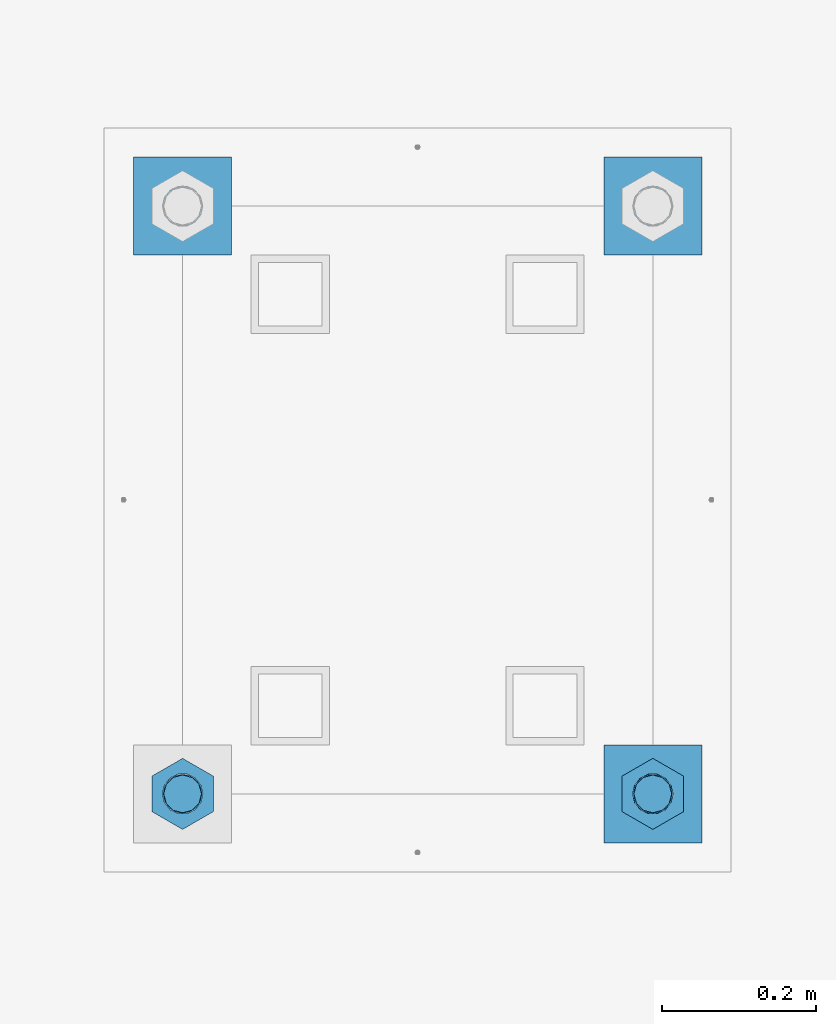
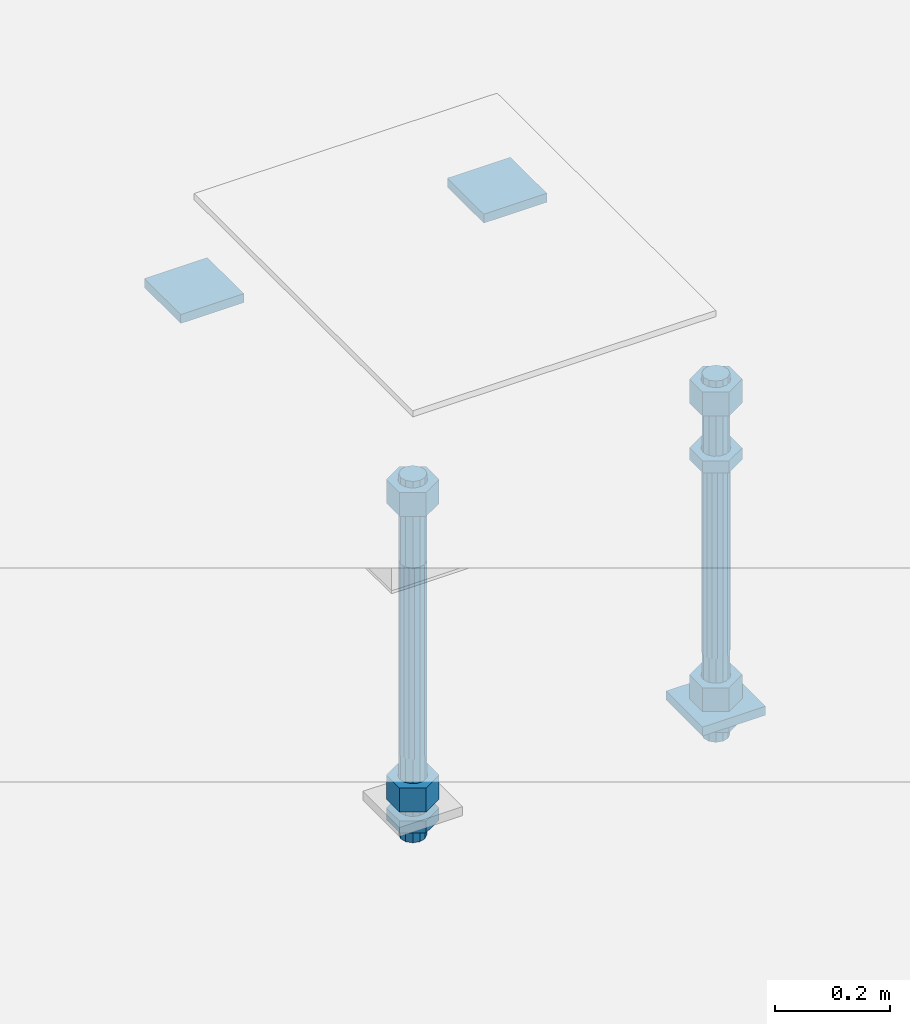
# One storey, part 2657 of 3843: 12 beams, 1 element without a shape of its own.
"""IFC2X3 building model written with IfcOpenShell, lengths in millimetres."""

import ifcopenshell
import ifcopenshell.guid

model = None  # the IFC model being written
_history = None  # IfcOwnerHistory: only IFC2X3 demands one
_inside = {}  # id of a spatial element -> (the spatial element, [elements in it])
_under = {}  # id of a project, library or spatial element -> (it, [spatial elements below it])
_declared = {}  # id of a project -> (the project, [libraries it declares])
_typed = {}  # id of a type object -> (the type object, [elements of that type])
_made_of = {}  # id of a material, layer set ... -> (it, [elements and type objects made of it])


def new_model(schema):
    """Start an empty IFC model of exactly this schema.

    Asked for "IFC4X3", IfcOpenShell would pick the latest addendum, in which some entities
    have other attributes; the version numbers below select the first issue.
    IFC2X3 requires an IfcOwnerHistory on every rooted entity: one is made here for all.
    """
    global model, _history
    if schema == "IFC4X3":
        model = ifcopenshell.file(schema_version=(4, 3, 0, 0))
    else:
        model = ifcopenshell.file(schema=schema)
    _inside.clear()
    _under.clear()
    _declared.clear()
    _typed.clear()
    _made_of.clear()
    _history = None
    if model.schema == "IFC2X3":
        org = make("IfcOrganization", Name="unknown")
        user = make(
            "IfcPersonAndOrganization",
            ThePerson=make("IfcPerson", FamilyName="unknown"),
            TheOrganization=org,
        )
        app = make(
            "IfcApplication",
            ApplicationDeveloper=org,
            Version="unknown",
            ApplicationFullName="unknown",
            ApplicationIdentifier="unknown",
        )
        _history = make(
            "IfcOwnerHistory",
            OwningUser=user,
            OwningApplication=app,
            ChangeAction="ADDED",
            CreationDate=0,
        )
    return model


def make(cls, **values):
    """One entity of the class cls with the attributes given. An attribute that is None is left unset."""
    return model.create_entity(
        cls, **{name: value for name, value in values.items() if value is not None}
    )


def rooted(cls, **values):
    """An entity with a GlobalId (a new one), such as an element, a storey or a relation."""
    return make(cls, GlobalId=ifcopenshell.guid.new(), OwnerHistory=_history, **values)


def si_unit(unit_type, name, prefix=None):
    """IfcSIUnit, for example si_unit("LENGTHUNIT", "METRE", prefix="MILLI")."""
    return make("IfcSIUnit", UnitType=unit_type, Prefix=prefix, Name=name)


def assignment(units):
    """IfcUnitAssignment: the units of a project."""
    return None if units is None else make("IfcUnitAssignment", Units=units)


def point(xyz):
    """IfcCartesianPoint."""
    return None if xyz is None else make("IfcCartesianPoint", Coordinates=xyz)


def direction(xyz):
    """IfcDirection."""
    return None if xyz is None else make("IfcDirection", DirectionRatios=xyz)


def frame(location, z_axis=None, x_axis=None):
    """IfcAxis2Placement3D, a coordinate frame: its origin and axes. An axis left out is left unset."""
    return make(
        "IfcAxis2Placement3D",
        Location=point(location),
        Axis=direction(z_axis),
        RefDirection=direction(x_axis),
    )


def origin_with_axes():
    """The frame at (0, 0, 0) with the z axis (0, 0, 1) and the x axis (1, 0, 0) written out."""
    return frame((0.0, 0.0, 0.0), z_axis=(0.0, 0.0, 1.0), x_axis=(1.0, 0.0, 0.0))


def place(relative_to, where):
    """IfcLocalPlacement: puts the frame where relative to a parent placement (None: the world)."""
    return make(
        "IfcLocalPlacement", PlacementRelTo=relative_to, RelativePlacement=where
    )


def context(
    kind, dimensions, precision=None, world=None, true_north=None, identifier=None
):
    """IfcGeometricRepresentationContext, for example the 3D "Model" context."""
    return make(
        "IfcGeometricRepresentationContext",
        ContextIdentifier=identifier,
        ContextType=kind,
        CoordinateSpaceDimension=dimensions,
        Precision=precision,
        WorldCoordinateSystem=world,
        TrueNorth=true_north,
    )


def subcontext(parent, identifier, kind, view, scale=None):
    """IfcGeometricRepresentationSubContext, for example "Body" below "Model"."""
    return make(
        "IfcGeometricRepresentationSubContext",
        ContextIdentifier=identifier,
        ContextType=kind,
        ParentContext=parent,
        TargetScale=scale,
        TargetView=view,
    )


def project(units=None, contexts=None):
    """IfcProject with its units and contexts."""
    return rooted(
        "IfcProject",
        Name="project",
        RepresentationContexts=contexts,
        UnitsInContext=assignment(units),
    )


def spatial(cls, under=None, at=None, **own):
    """A site, building, storey or space (cls), placed at a placement, below another one or the project."""
    s = rooted(cls, ObjectPlacement=at, **own)
    if under is not None:
        _under.setdefault(under.id(), (under, []))[1].append(s)
    return s


def faces_of(points, faces, orient=None, outer=None):
    """IfcFace entities. A face is a list of loops; a loop is a list of indices into points, from 0.

    orient and outer hold one flag for each loop. By default every Orientation is true, the
    first loop of a face is its IfcFaceOuterBound and the others are IfcFaceBound.
    """
    made = []
    for i, loops in enumerate(faces):
        bounds = []
        for j, loop in enumerate(loops):
            is_outer = j == 0 if outer is None else outer[i][j]
            bounds.append(
                make(
                    "IfcFaceOuterBound" if is_outer else "IfcFaceBound",
                    Bound=make("IfcPolyLoop", Polygon=[points[k] for k in loop]),
                    Orientation=True if orient is None else orient[i][j],
                )
            )
        made.append(make("IfcFace", Bounds=bounds))
    return made


def faceted_brep(points, faces, orient=None, outer=None, voids=None):
    """IfcFacetedBrep: a solid bounded by flat faces; with voids (closed shells), ...WithVoids."""
    shared = [point(p) for p in points]
    hull = make("IfcClosedShell", CfsFaces=faces_of(shared, faces, orient, outer))
    if voids is None:
        return make("IfcFacetedBrep", Outer=hull)
    return make(
        "IfcFacetedBrepWithVoids",
        Outer=hull,
        Voids=[
            make(cls, CfsFaces=faces_of(shared, fs, o, b)) for cls, fs, o, b in voids
        ],
    )


def shape(context_of_items, identifier, shape_type, items):
    """IfcShapeRepresentation: the items that make up one representation, for example the "Body"."""
    return make(
        "IfcShapeRepresentation",
        ContextOfItems=context_of_items,
        RepresentationIdentifier=identifier,
        RepresentationType=shape_type,
        Items=items,
    )


def material(Name=None, Category=None):
    """IfcMaterial."""
    return make("IfcMaterial", Name=Name, Category=Category)


def made_of(thing, what):
    """Note that an element or type object is made of a material, layer set ...; save() writes the relation."""
    if what is not None:
        _made_of.setdefault(what.id(), (what, []))[1].append(thing)
    return thing


def type_object(cls, material=None, **own):
    """A type object (cls), such as IfcWallType, which elements share."""
    return made_of(rooted(cls, **own), material)


def element(
    cls,
    number,
    at=None,
    inside=None,
    cuts=None,
    type_object=None,
    material=None,
    context=None,
    identifier="Body",
    shape_type=None,
    held_by="IfcProductDefinitionShape",
    body=None,
    shapes=None,
    **own,
):
    """One element of the class cls, such as IfcWall. Its Tag is "e" and its number.

    at: its placement. inside: the storey or other place that contains it. cuts: it is an
    opening in that element (IfcRelVoidsElement). A single representation is given by context,
    identifier, shape_type and body (its items); several are given by shapes. held_by: the class
    of the entity that holds the representations. save() writes the other relations.
    """
    e = rooted(cls, Tag="e%d" % number, ObjectPlacement=at, **own)
    if body is not None:
        shapes = [shape(context, identifier, shape_type, body)]
    if shapes is not None:
        e.Representation = make(held_by, Representations=shapes)
    if inside is not None:
        _inside.setdefault(inside.id(), (inside, []))[1].append(e)
    if cuts is not None:
        rooted(
            "IfcRelVoidsElement", RelatingBuildingElement=cuts, RelatedOpeningElement=e
        )
    if type_object is not None:
        _typed.setdefault(type_object.id(), (type_object, []))[1].append(e)
    return made_of(e, material)


def aggregate(whole, parts):
    """IfcRelAggregates: a whole, such as a stair, and the parts it consists of."""
    return rooted("IfcRelAggregates", RelatingObject=whole, RelatedObjects=parts)


def save(model, path):
    """Write the relations noted so far, then the file.

    IfcRelAggregates (storeys below a building ...), IfcRelContainedInSpatialStructure (elements
    in a storey), IfcRelDefinesByType, IfcRelAssociatesMaterial and IfcRelDeclares: one each for
    every whole, place, type object, material and project.
    """
    for whole, parts in _under.values():
        aggregate(whole, parts)
    for where, things in _inside.values():
        rooted(
            "IfcRelContainedInSpatialStructure",
            RelatedElements=things,
            RelatingStructure=where,
        )
    for kind, things in _typed.values():
        rooted("IfcRelDefinesByType", RelatedObjects=things, RelatingType=kind)
    for what, things in _made_of.values():
        rooted("IfcRelAssociatesMaterial", RelatedObjects=things, RelatingMaterial=what)
    for by, libraries in _declared.values():
        rooted("IfcRelDeclares", RelatingContext=by, RelatedDefinitions=libraries)
    model.write(path)


model = new_model("IFC2X3")

# Units and contexts
model_context = context("Model", 3, precision=1e-05, world=origin_with_axes())
body_context = subcontext(model_context, "Body", "Model", "MODEL_VIEW")
ifc_project = project(units=[si_unit("LENGTHUNIT", "METRE", prefix="MILLI"), si_unit("AREAUNIT", "SQUARE_METRE"), si_unit("VOLUMEUNIT", "CUBIC_METRE"), si_unit("MASSUNIT", "GRAM", prefix="KILO"), si_unit("TIMEUNIT", "SECOND"), si_unit("PLANEANGLEUNIT", "RADIAN"), si_unit("SOLIDANGLEUNIT", "STERADIAN"), si_unit("THERMODYNAMICTEMPERATUREUNIT", "DEGREE_CELSIUS"), si_unit("LUMINOUSINTENSITYUNIT", "LUMEN")], contexts=[model_context])

# Site, building, storey
site_placement = place(None, origin_with_axes())
site = spatial("IfcSite", under=ifc_project, at=site_placement, CompositionType="ELEMENT")
building_placement = place(site_placement, origin_with_axes())
building = spatial("IfcBuilding", under=site, at=building_placement, Name="Undefined", CompositionType="ELEMENT")
storey_placement = place(building_placement, origin_with_axes())
storey = spatial("IfcBuildingStorey", under=building, at=storey_placement, Name="Undefined", CompositionType="ELEMENT", Elevation=0.0)

# Assembly, beams
assembly_placement = place(storey_placement, origin_with_axes())
assembly = element("IfcElementAssembly", 1, at=assembly_placement, inside=storey, Name="TEMPLATE", AssemblyPlace="NOTDEFINED", PredefinedType="RIGID_FRAME")
ifc_material_1 = material(Name="STEEL/A36")
beam_type_1 = type_object("IfcBeamType", PredefinedType="NOTDEFINED")
beam_1_placement = place(assembly_placement, frame((116471.7, 18199.1, 29873.575), z_axis=(0.0, 1.0, 0.0), x_axis=(-1.0, 0.0, 0.0)))
beam_1 = element("IfcBeam", 2, at=beam_1_placement, type_object=beam_type_1, material=ifc_material_1, Name="WASHER_PLATE", context=body_context, shape_type="Brep", body=[
    faceted_brep([(0.0, 9.52500000000146, -63.5), (0.0, 9.52500000000146, 63.5), (127.0, 9.52500000000146, 63.5), (127.0, 9.52500000000146, -63.5), (0.0, -9.52500000000146, 63.5), (127.0, -9.52500000000146, 63.5), (0.0, -9.52500000000146, -63.5), (127.0, -9.52500000000146, -63.5)], [[[0, 1, 2, 3]], [[1, 4, 5, 2]], [[4, 6, 7, 5]], [[6, 0, 3, 7]], [[5, 7, 3, 2]], [[6, 4, 1, 0]]]),
])
beam_2_placement = place(assembly_placement, frame((115862.099998474, 18199.1, 29873.575), z_axis=(0.0, 1.0, 0.0), x_axis=(-1.0, 0.0, 0.0)))
beam_2 = element("IfcBeam", 3, at=beam_2_placement, type_object=beam_type_1, material=ifc_material_1, Name="WASHER_PLATE", context=body_context, shape_type="Brep", body=[
    faceted_brep([(0.0, 9.52500000000146, -63.5), (0.0, 9.52500000000146, 63.5), (127.0, 9.52500000000146, 63.5), (127.0, 9.52500000000146, -63.5), (0.0, -9.52500000000146, 63.5), (127.0, -9.52500000000146, 63.5), (0.0, -9.52500000000146, -63.5), (127.0, -9.52500000000146, -63.5)], [[[0, 1, 2, 3]], [[1, 4, 5, 2]], [[4, 6, 7, 5]], [[6, 0, 3, 7]], [[5, 7, 3, 2]], [[6, 4, 1, 0]]]),
])
beam_3_placement = place(assembly_placement, frame((116471.7, 17437.1, 29244.925), z_axis=(0.0, 1.0, 0.0), x_axis=(-1.0, 0.0, 0.0)))
beam_3 = element("IfcBeam", 4, at=beam_3_placement, type_object=beam_type_1, material=ifc_material_1, Name="WASHER_PLATE", context=body_context, shape_type="Brep", body=[
    faceted_brep([(0.0, 9.52500000000146, -63.5), (0.0, 9.52500000000146, 63.5), (127.0, 9.52500000000146, 63.5), (127.0, 9.52500000000146, -63.5), (0.0, -9.52500000000146, 63.5), (127.0, -9.52500000000146, 63.5), (0.0, -9.52500000000146, -63.5), (127.0, -9.52500000000146, -63.5)], [[[0, 1, 2, 3]], [[1, 4, 5, 2]], [[4, 6, 7, 5]], [[6, 0, 3, 7]], [[5, 7, 3, 2]], [[6, 4, 1, 0]]]),
])
beam_type_2 = type_object("IfcBeamType", Name="2_HALF_NUT", PredefinedType="NOTDEFINED")
beam_4_placement = place(assembly_placement, frame((115798.599998474, 17437.1, 29235.4), z_axis=(-1.0, 0.0, 0.0), x_axis=(0.0, 0.0, -1.0)))
beam_4 = element("IfcBeam", 5, at=beam_4_placement, type_object=beam_type_2, material=ifc_material_1, Name="NUT", ObjectType="2_HALF_NUT", context=body_context, shape_type="Brep", body=[
    faceted_brep([(0.0, -46.0369987487793, 0.0), (0.0, -23.0184993743896, -39.869213104248), (25.4000000000015, -23.0184993743896, -39.869213104248), (25.4000000000015, -46.0369987487793, 0.0), (0.0, 23.0184993743896, -39.869213104248), (25.4000000000015, 23.0184993743896, -39.869213104248), (0.0, 46.0369987487793, 0.0), (25.4000000000015, 46.0369987487793, 0.0), (0.0, 23.0184993743896, 39.869213104248), (25.4000000000015, 23.0184993743896, 39.869213104248), (0.0, -23.0184993743896, 39.869213104248), (25.4000000000015, -23.0184993743896, 39.869213104248), (0.0, 0.0, 26.1940002441406), (0.0, 11.3650617044477, 23.5999013092805), (25.4000000000015, 11.3650617044477, 23.5999013092805), (25.4000000000015, 0.0, 26.1940002441406), (0.0, 20.4791109456419, 16.3316083006721), (25.4000000000015, 20.4791109456419, 16.3316083006721), (0.0, 25.5370200498292, 5.82867859874386), (25.4000000000015, 25.5370200498292, 5.82867859874386), (0.0, 25.5370200498292, -5.82867859874386), (25.4000000000015, 25.5370200498292, -5.82867859874386), (0.0, 20.4791109456419, -16.3316083006721), (25.4000000000015, 20.4791109456419, -16.3316083006721), (0.0, 11.3650617044477, -23.5999013092805), (25.4000000000015, 11.3650617044477, -23.5999013092805), (0.0, 0.0, -26.1940002441406), (25.4000000000015, 0.0, -26.1940002441406), (0.0, -11.3650617044477, -23.5999013092805), (25.4000000000015, -11.3650617044477, -23.5999013092805), (0.0, -20.4791109456419, -16.3316083006721), (25.4000000000015, -20.4791109456419, -16.3316083006721), (0.0, -25.5370200498292, -5.82867859874386), (25.4000000000015, -25.5370200498292, -5.82867859874386), (0.0, -25.5370200498292, 5.82867859874386), (25.4000000000015, -25.5370200498292, 5.82867859874386), (0.0, -20.4791109456419, 16.3316083006721), (25.4000000000015, -20.4791109456419, 16.3316083006721), (0.0, -11.3650617044477, 23.5999013092805), (25.4000000000015, -11.3650617044477, 23.5999013092805)], [[[0, 1, 2, 3]], [[1, 4, 5, 2]], [[4, 6, 7, 5]], [[6, 8, 9, 7]], [[8, 10, 11, 9]], [[10, 0, 3, 11]], [[12, 13, 14, 15]], [[13, 16, 17, 14]], [[16, 18, 19, 17]], [[18, 20, 21, 19]], [[20, 22, 23, 21]], [[22, 24, 25, 23]], [[24, 26, 27, 25]], [[26, 28, 29, 27]], [[28, 30, 31, 29]], [[30, 32, 33, 31]], [[32, 34, 35, 33]], [[34, 36, 37, 35]], [[36, 38, 39, 37]], [[38, 12, 15, 39]], [[5, 7, 9, 11, 3, 2], [17, 19, 21, 23, 25, 27, 29, 31, 33, 35, 37, 39, 15, 14]], [[10, 8, 6, 4, 1, 0], [38, 36, 34, 32, 30, 28, 26, 24, 22, 20, 18, 16, 13, 12]]]),
])
beam_5_placement = place(assembly_placement, frame((116408.2, 17437.1, 29787.85), z_axis=(-1.0, 0.0, 0.0), x_axis=(0.0, 0.0, -1.0)))
beam_5 = element("IfcBeam", 6, at=beam_5_placement, type_object=beam_type_2, material=ifc_material_1, Name="NUT", ObjectType="2_HALF_NUT", context=body_context, shape_type="Brep", body=[
    faceted_brep([(0.0, -46.0369987487793, 0.0), (0.0, -23.0184993743896, -39.869213104248), (25.4000000000015, -23.0184993743896, -39.869213104248), (25.4000000000015, -46.0369987487793, 0.0), (0.0, 23.0184993743896, -39.869213104248), (25.4000000000015, 23.0184993743896, -39.869213104248), (0.0, 46.0369987487793, 0.0), (25.4000000000015, 46.0369987487793, 0.0), (0.0, 23.0184993743896, 39.869213104248), (25.4000000000015, 23.0184993743896, 39.869213104248), (0.0, -23.0184993743896, 39.869213104248), (25.4000000000015, -23.0184993743896, 39.869213104248), (0.0, 0.0, 26.1940002441406), (0.0, 11.3650617044477, 23.5999013092805), (25.4000000000015, 11.3650617044477, 23.5999013092805), (25.4000000000015, 0.0, 26.1940002441406), (0.0, 20.4791109456419, 16.3316083006721), (25.4000000000015, 20.4791109456419, 16.3316083006721), (0.0, 25.5370200498292, 5.82867859874386), (25.4000000000015, 25.5370200498292, 5.82867859874386), (0.0, 25.5370200498292, -5.82867859874386), (25.4000000000015, 25.5370200498292, -5.82867859874386), (0.0, 20.4791109456419, -16.3316083006721), (25.4000000000015, 20.4791109456419, -16.3316083006721), (0.0, 11.3650617044477, -23.5999013092805), (25.4000000000015, 11.3650617044477, -23.5999013092805), (0.0, 0.0, -26.1940002441406), (25.4000000000015, 0.0, -26.1940002441406), (0.0, -11.3650617044477, -23.5999013092805), (25.4000000000015, -11.3650617044477, -23.5999013092805), (0.0, -20.4791109456419, -16.3316083006721), (25.4000000000015, -20.4791109456419, -16.3316083006721), (0.0, -25.5370200498292, -5.82867859874386), (25.4000000000015, -25.5370200498292, -5.82867859874386), (0.0, -25.5370200498292, 5.82867859874386), (25.4000000000015, -25.5370200498292, 5.82867859874386), (0.0, -20.4791109456419, 16.3316083006721), (25.4000000000015, -20.4791109456419, 16.3316083006721), (0.0, -11.3650617044477, 23.5999013092805), (25.4000000000015, -11.3650617044477, 23.5999013092805)], [[[0, 1, 2, 3]], [[1, 4, 5, 2]], [[4, 6, 7, 5]], [[6, 8, 9, 7]], [[8, 10, 11, 9]], [[10, 0, 3, 11]], [[12, 13, 14, 15]], [[13, 16, 17, 14]], [[16, 18, 19, 17]], [[18, 20, 21, 19]], [[20, 22, 23, 21]], [[22, 24, 25, 23]], [[24, 26, 27, 25]], [[26, 28, 29, 27]], [[28, 30, 31, 29]], [[30, 32, 33, 31]], [[32, 34, 35, 33]], [[34, 36, 37, 35]], [[36, 38, 39, 37]], [[38, 12, 15, 39]], [[5, 7, 9, 11, 3, 2], [17, 19, 21, 23, 25, 27, 29, 31, 33, 35, 37, 39, 15, 14]], [[10, 8, 6, 4, 1, 0], [38, 36, 34, 32, 30, 28, 26, 24, 22, 20, 18, 16, 13, 12]]]),
])
beam_6_placement = place(assembly_placement, frame((116408.2, 17437.1, 29235.4), z_axis=(-1.0, 0.0, 0.0), x_axis=(0.0, 0.0, -1.0)))
beam_6 = element("IfcBeam", 7, at=beam_6_placement, type_object=beam_type_2, material=ifc_material_1, Name="NUT", ObjectType="2_HALF_NUT", context=body_context, shape_type="Brep", body=[
    faceted_brep([(0.0, -46.0369987487793, 0.0), (0.0, -23.0184993743896, -39.869213104248), (25.4000000000015, -23.0184993743896, -39.869213104248), (25.4000000000015, -46.0369987487793, 0.0), (0.0, 23.0184993743896, -39.869213104248), (25.4000000000015, 23.0184993743896, -39.869213104248), (0.0, 46.0369987487793, 0.0), (25.4000000000015, 46.0369987487793, 0.0), (0.0, 23.0184993743896, 39.869213104248), (25.4000000000015, 23.0184993743896, 39.869213104248), (0.0, -23.0184993743896, 39.869213104248), (25.4000000000015, -23.0184993743896, 39.869213104248), (0.0, 0.0, 26.1940002441406), (0.0, 11.3650617044477, 23.5999013092805), (25.4000000000015, 11.3650617044477, 23.5999013092805), (25.4000000000015, 0.0, 26.1940002441406), (0.0, 20.4791109456419, 16.3316083006721), (25.4000000000015, 20.4791109456419, 16.3316083006721), (0.0, 25.5370200498292, 5.82867859874386), (25.4000000000015, 25.5370200498292, 5.82867859874386), (0.0, 25.5370200498292, -5.82867859874386), (25.4000000000015, 25.5370200498292, -5.82867859874386), (0.0, 20.4791109456419, -16.3316083006721), (25.4000000000015, 20.4791109456419, -16.3316083006721), (0.0, 11.3650617044477, -23.5999013092805), (25.4000000000015, 11.3650617044477, -23.5999013092805), (0.0, 0.0, -26.1940002441406), (25.4000000000015, 0.0, -26.1940002441406), (0.0, -11.3650617044477, -23.5999013092805), (25.4000000000015, -11.3650617044477, -23.5999013092805), (0.0, -20.4791109456419, -16.3316083006721), (25.4000000000015, -20.4791109456419, -16.3316083006721), (0.0, -25.5370200498292, -5.82867859874386), (25.4000000000015, -25.5370200498292, -5.82867859874386), (0.0, -25.5370200498292, 5.82867859874386), (25.4000000000015, -25.5370200498292, 5.82867859874386), (0.0, -20.4791109456419, 16.3316083006721), (25.4000000000015, -20.4791109456419, 16.3316083006721), (0.0, -11.3650617044477, 23.5999013092805), (25.4000000000015, -11.3650617044477, 23.5999013092805)], [[[0, 1, 2, 3]], [[1, 4, 5, 2]], [[4, 6, 7, 5]], [[6, 8, 9, 7]], [[8, 10, 11, 9]], [[10, 0, 3, 11]], [[12, 13, 14, 15]], [[13, 16, 17, 14]], [[16, 18, 19, 17]], [[18, 20, 21, 19]], [[20, 22, 23, 21]], [[22, 24, 25, 23]], [[24, 26, 27, 25]], [[26, 28, 29, 27]], [[28, 30, 31, 29]], [[30, 32, 33, 31]], [[32, 34, 35, 33]], [[34, 36, 37, 35]], [[36, 38, 39, 37]], [[38, 12, 15, 39]], [[5, 7, 9, 11, 3, 2], [17, 19, 21, 23, 25, 27, 29, 31, 33, 35, 37, 39, 15, 14]], [[10, 8, 6, 4, 1, 0], [38, 36, 34, 32, 30, 28, 26, 24, 22, 20, 18, 16, 13, 12]]]),
])
beam_type_3 = type_object("IfcBeamType", Name="2_HEAVY_HEX_NUT", PredefinedType="NOTDEFINED")
beam_7_placement = place(assembly_placement, frame((115798.599998474, 17437.1, 29933.9), z_axis=(-1.0, 0.0, 0.0), x_axis=(0.0, 0.0, -1.0)))
beam_7 = element("IfcBeam", 8, at=beam_7_placement, type_object=beam_type_3, material=ifc_material_1, Name="NUT", ObjectType="2_HEAVY_HEX_NUT", context=body_context, shape_type="Brep", body=[
    faceted_brep([(0.0, -46.0369987487793, 0.0), (0.0, -23.0184993743896, -39.869213104248), (50.7999999999993, -23.0184993743896, -39.869213104248), (50.7999999999993, -46.0369987487793, 0.0), (0.0, 23.0184993743896, -39.869213104248), (50.7999999999993, 23.0184993743896, -39.869213104248), (0.0, 46.0369987487793, 0.0), (50.7999999999993, 46.0369987487793, 0.0), (0.0, 23.0184993743896, 39.869213104248), (50.7999999999993, 23.0184993743896, 39.869213104248), (0.0, -23.0184993743896, 39.869213104248), (50.7999999999993, -23.0184993743896, 39.869213104248), (0.0, 0.0, 26.1940002441406), (0.0, 11.3650617044477, 23.5999013092805), (50.7999999999993, 11.3650617044477, 23.5999013092805), (50.7999999999993, 0.0, 26.1940002441406), (0.0, 20.4791109456419, 16.3316083006721), (50.7999999999993, 20.4791109456419, 16.3316083006721), (0.0, 25.5370200498292, 5.82867859874386), (50.7999999999993, 25.5370200498292, 5.82867859874386), (0.0, 25.5370200498292, -5.82867859874386), (50.7999999999993, 25.5370200498292, -5.82867859874386), (0.0, 20.4791109456419, -16.3316083006721), (50.7999999999993, 20.4791109456419, -16.3316083006721), (0.0, 11.3650617044477, -23.5999013092805), (50.7999999999993, 11.3650617044477, -23.5999013092805), (0.0, 0.0, -26.1940002441406), (50.7999999999993, 0.0, -26.1940002441406), (0.0, -11.3650617044477, -23.5999013092805), (50.7999999999993, -11.3650617044477, -23.5999013092805), (0.0, -20.4791109456419, -16.3316083006721), (50.7999999999993, -20.4791109456419, -16.3316083006721), (0.0, -25.5370200498292, -5.82867859874386), (50.7999999999993, -25.5370200498292, -5.82867859874386), (0.0, -25.5370200498292, 5.82867859874386), (50.7999999999993, -25.5370200498292, 5.82867859874386), (0.0, -20.4791109456419, 16.3316083006721), (50.7999999999993, -20.4791109456419, 16.3316083006721), (0.0, -11.3650617044477, 23.5999013092805), (50.7999999999993, -11.3650617044477, 23.5999013092805)], [[[0, 1, 2, 3]], [[1, 4, 5, 2]], [[4, 6, 7, 5]], [[6, 8, 9, 7]], [[8, 10, 11, 9]], [[10, 0, 3, 11]], [[12, 13, 14, 15]], [[13, 16, 17, 14]], [[16, 18, 19, 17]], [[18, 20, 21, 19]], [[20, 22, 23, 21]], [[22, 24, 25, 23]], [[24, 26, 27, 25]], [[26, 28, 29, 27]], [[28, 30, 31, 29]], [[30, 32, 33, 31]], [[32, 34, 35, 33]], [[34, 36, 37, 35]], [[36, 38, 39, 37]], [[38, 12, 15, 39]], [[5, 7, 9, 11, 3, 2], [17, 19, 21, 23, 25, 27, 29, 31, 33, 35, 37, 39, 15, 14]], [[10, 8, 6, 4, 1, 0], [38, 36, 34, 32, 30, 28, 26, 24, 22, 20, 18, 16, 13, 12]]]),
])
beam_8_placement = place(assembly_placement, frame((115798.599998474, 17437.1, 29305.25), z_axis=(-1.0, 0.0, 0.0), x_axis=(0.0, 0.0, -1.0)))
beam_8 = element("IfcBeam", 9, at=beam_8_placement, type_object=beam_type_3, material=ifc_material_1, Name="NUT", ObjectType="2_HEAVY_HEX_NUT", context=body_context, shape_type="Brep", body=[
    faceted_brep([(0.0, -46.0369987487793, 0.0), (0.0, -23.0184993743896, -39.869213104248), (50.7999999999993, -23.0184993743896, -39.869213104248), (50.7999999999993, -46.0369987487793, 0.0), (0.0, 23.0184993743896, -39.869213104248), (50.7999999999993, 23.0184993743896, -39.869213104248), (0.0, 46.0369987487793, 0.0), (50.7999999999993, 46.0369987487793, 0.0), (0.0, 23.0184993743896, 39.869213104248), (50.7999999999993, 23.0184993743896, 39.869213104248), (0.0, -23.0184993743896, 39.869213104248), (50.7999999999993, -23.0184993743896, 39.869213104248), (0.0, 0.0, 26.1940002441406), (0.0, 11.3650617044477, 23.5999013092805), (50.7999999999993, 11.3650617044477, 23.5999013092805), (50.7999999999993, 0.0, 26.1940002441406), (0.0, 20.4791109456419, 16.3316083006721), (50.7999999999993, 20.4791109456419, 16.3316083006721), (0.0, 25.5370200498292, 5.82867859874386), (50.7999999999993, 25.5370200498292, 5.82867859874386), (0.0, 25.5370200498292, -5.82867859874386), (50.7999999999993, 25.5370200498292, -5.82867859874386), (0.0, 20.4791109456419, -16.3316083006721), (50.7999999999993, 20.4791109456419, -16.3316083006721), (0.0, 11.3650617044477, -23.5999013092805), (50.7999999999993, 11.3650617044477, -23.5999013092805), (0.0, 0.0, -26.1940002441406), (50.7999999999993, 0.0, -26.1940002441406), (0.0, -11.3650617044477, -23.5999013092805), (50.7999999999993, -11.3650617044477, -23.5999013092805), (0.0, -20.4791109456419, -16.3316083006721), (50.7999999999993, -20.4791109456419, -16.3316083006721), (0.0, -25.5370200498292, -5.82867859874386), (50.7999999999993, -25.5370200498292, -5.82867859874386), (0.0, -25.5370200498292, 5.82867859874386), (50.7999999999993, -25.5370200498292, 5.82867859874386), (0.0, -20.4791109456419, 16.3316083006721), (50.7999999999993, -20.4791109456419, 16.3316083006721), (0.0, -11.3650617044477, 23.5999013092805), (50.7999999999993, -11.3650617044477, 23.5999013092805)], [[[0, 1, 2, 3]], [[1, 4, 5, 2]], [[4, 6, 7, 5]], [[6, 8, 9, 7]], [[8, 10, 11, 9]], [[10, 0, 3, 11]], [[12, 13, 14, 15]], [[13, 16, 17, 14]], [[16, 18, 19, 17]], [[18, 20, 21, 19]], [[20, 22, 23, 21]], [[22, 24, 25, 23]], [[24, 26, 27, 25]], [[26, 28, 29, 27]], [[28, 30, 31, 29]], [[30, 32, 33, 31]], [[32, 34, 35, 33]], [[34, 36, 37, 35]], [[36, 38, 39, 37]], [[38, 12, 15, 39]], [[5, 7, 9, 11, 3, 2], [17, 19, 21, 23, 25, 27, 29, 31, 33, 35, 37, 39, 15, 14]], [[10, 8, 6, 4, 1, 0], [38, 36, 34, 32, 30, 28, 26, 24, 22, 20, 18, 16, 13, 12]]]),
])
beam_9_placement = place(assembly_placement, frame((116408.2, 17437.1, 29933.9), z_axis=(-1.0, 0.0, 0.0), x_axis=(0.0, 0.0, -1.0)))
beam_9 = element("IfcBeam", 10, at=beam_9_placement, type_object=beam_type_3, material=ifc_material_1, Name="NUT", ObjectType="2_HEAVY_HEX_NUT", context=body_context, shape_type="Brep", body=[
    faceted_brep([(0.0, -46.0369987487793, 0.0), (0.0, -23.0184993743896, -39.869213104248), (50.7999999999993, -23.0184993743896, -39.869213104248), (50.7999999999993, -46.0369987487793, 0.0), (0.0, 23.0184993743896, -39.869213104248), (50.7999999999993, 23.0184993743896, -39.869213104248), (0.0, 46.0369987487793, 0.0), (50.7999999999993, 46.0369987487793, 0.0), (0.0, 23.0184993743896, 39.869213104248), (50.7999999999993, 23.0184993743896, 39.869213104248), (0.0, -23.0184993743896, 39.869213104248), (50.7999999999993, -23.0184993743896, 39.869213104248), (0.0, 0.0, 26.1940002441406), (0.0, 11.3650617044477, 23.5999013092805), (50.7999999999993, 11.3650617044477, 23.5999013092805), (50.7999999999993, 0.0, 26.1940002441406), (0.0, 20.4791109456419, 16.3316083006721), (50.7999999999993, 20.4791109456419, 16.3316083006721), (0.0, 25.5370200498292, 5.82867859874386), (50.7999999999993, 25.5370200498292, 5.82867859874386), (0.0, 25.5370200498292, -5.82867859874386), (50.7999999999993, 25.5370200498292, -5.82867859874386), (0.0, 20.4791109456419, -16.3316083006721), (50.7999999999993, 20.4791109456419, -16.3316083006721), (0.0, 11.3650617044477, -23.5999013092805), (50.7999999999993, 11.3650617044477, -23.5999013092805), (0.0, 0.0, -26.1940002441406), (50.7999999999993, 0.0, -26.1940002441406), (0.0, -11.3650617044477, -23.5999013092805), (50.7999999999993, -11.3650617044477, -23.5999013092805), (0.0, -20.4791109456419, -16.3316083006721), (50.7999999999993, -20.4791109456419, -16.3316083006721), (0.0, -25.5370200498292, -5.82867859874386), (50.7999999999993, -25.5370200498292, -5.82867859874386), (0.0, -25.5370200498292, 5.82867859874386), (50.7999999999993, -25.5370200498292, 5.82867859874386), (0.0, -20.4791109456419, 16.3316083006721), (50.7999999999993, -20.4791109456419, 16.3316083006721), (0.0, -11.3650617044477, 23.5999013092805), (50.7999999999993, -11.3650617044477, 23.5999013092805)], [[[0, 1, 2, 3]], [[1, 4, 5, 2]], [[4, 6, 7, 5]], [[6, 8, 9, 7]], [[8, 10, 11, 9]], [[10, 0, 3, 11]], [[12, 13, 14, 15]], [[13, 16, 17, 14]], [[16, 18, 19, 17]], [[18, 20, 21, 19]], [[20, 22, 23, 21]], [[22, 24, 25, 23]], [[24, 26, 27, 25]], [[26, 28, 29, 27]], [[28, 30, 31, 29]], [[30, 32, 33, 31]], [[32, 34, 35, 33]], [[34, 36, 37, 35]], [[36, 38, 39, 37]], [[38, 12, 15, 39]], [[5, 7, 9, 11, 3, 2], [17, 19, 21, 23, 25, 27, 29, 31, 33, 35, 37, 39, 15, 14]], [[10, 8, 6, 4, 1, 0], [38, 36, 34, 32, 30, 28, 26, 24, 22, 20, 18, 16, 13, 12]]]),
])
beam_10_placement = place(assembly_placement, frame((116408.2, 17437.1, 29305.25), z_axis=(-1.0, 0.0, 0.0), x_axis=(0.0, 0.0, -1.0)))
beam_10 = element("IfcBeam", 11, at=beam_10_placement, type_object=beam_type_3, material=ifc_material_1, Name="NUT", ObjectType="2_HEAVY_HEX_NUT", context=body_context, shape_type="Brep", body=[
    faceted_brep([(0.0, -46.0369987487793, 0.0), (0.0, -23.0184993743896, -39.869213104248), (50.7999999999993, -23.0184993743896, -39.869213104248), (50.7999999999993, -46.0369987487793, 0.0), (0.0, 23.0184993743896, -39.869213104248), (50.7999999999993, 23.0184993743896, -39.869213104248), (0.0, 46.0369987487793, 0.0), (50.7999999999993, 46.0369987487793, 0.0), (0.0, 23.0184993743896, 39.869213104248), (50.7999999999993, 23.0184993743896, 39.869213104248), (0.0, -23.0184993743896, 39.869213104248), (50.7999999999993, -23.0184993743896, 39.869213104248), (0.0, 0.0, 26.1940002441406), (0.0, 11.3650617044477, 23.5999013092805), (50.7999999999993, 11.3650617044477, 23.5999013092805), (50.7999999999993, 0.0, 26.1940002441406), (0.0, 20.4791109456419, 16.3316083006721), (50.7999999999993, 20.4791109456419, 16.3316083006721), (0.0, 25.5370200498292, 5.82867859874386), (50.7999999999993, 25.5370200498292, 5.82867859874386), (0.0, 25.5370200498292, -5.82867859874386), (50.7999999999993, 25.5370200498292, -5.82867859874386), (0.0, 20.4791109456419, -16.3316083006721), (50.7999999999993, 20.4791109456419, -16.3316083006721), (0.0, 11.3650617044477, -23.5999013092805), (50.7999999999993, 11.3650617044477, -23.5999013092805), (0.0, 0.0, -26.1940002441406), (50.7999999999993, 0.0, -26.1940002441406), (0.0, -11.3650617044477, -23.5999013092805), (50.7999999999993, -11.3650617044477, -23.5999013092805), (0.0, -20.4791109456419, -16.3316083006721), (50.7999999999993, -20.4791109456419, -16.3316083006721), (0.0, -25.5370200498292, -5.82867859874386), (50.7999999999993, -25.5370200498292, -5.82867859874386), (0.0, -25.5370200498292, 5.82867859874386), (50.7999999999993, -25.5370200498292, 5.82867859874386), (0.0, -20.4791109456419, 16.3316083006721), (50.7999999999993, -20.4791109456419, 16.3316083006721), (0.0, -11.3650617044477, 23.5999013092805), (50.7999999999993, -11.3650617044477, 23.5999013092805)], [[[0, 1, 2, 3]], [[1, 4, 5, 2]], [[4, 6, 7, 5]], [[6, 8, 9, 7]], [[8, 10, 11, 9]], [[10, 0, 3, 11]], [[12, 13, 14, 15]], [[13, 16, 17, 14]], [[16, 18, 19, 17]], [[18, 20, 21, 19]], [[20, 22, 23, 21]], [[22, 24, 25, 23]], [[24, 26, 27, 25]], [[26, 28, 29, 27]], [[28, 30, 31, 29]], [[30, 32, 33, 31]], [[32, 34, 35, 33]], [[34, 36, 37, 35]], [[36, 38, 39, 37]], [[38, 12, 15, 39]], [[5, 7, 9, 11, 3, 2], [17, 19, 21, 23, 25, 27, 29, 31, 33, 35, 37, 39, 15, 14]], [[10, 8, 6, 4, 1, 0], [38, 36, 34, 32, 30, 28, 26, 24, 22, 20, 18, 16, 13, 12]]]),
])
ifc_material_2 = material()
beam_type_4 = type_object("IfcBeamType", PredefinedType="NOTDEFINED")
beam_11_placement = place(assembly_placement, frame((115798.599998474, 17437.1, 29762.45), z_axis=(-1.0, 0.0, 0.0), x_axis=(0.0, 0.0, -1.0)))
beam_11 = element("IfcBeam", 12, at=beam_11_placement, type_object=beam_type_4, material=ifc_material_2, Name="ANCHOR_ROD", context=body_context, shape_type="Brep", body=[
    faceted_brep([(-184.150000000001, -21.217622392709, 12.25), (-184.150000000001, -12.2499999999854, 21.2176223927163), (-184.150000000001, 1.45519152283669e-11, 24.5), (-184.150000000001, 12.2500000000146, 21.2176223927163), (-184.150000000001, 21.2176223927381, 12.25), (-184.150000000001, 24.5000000000146, 0.0), (-184.150000000001, 21.2176223927381, -12.25), (-184.150000000001, 12.2500000000146, -21.2176223927163), (-184.150000000001, 1.45519152283669e-11, -24.5), (-184.150000000001, -12.2499999999854, -21.2176223927163), (-184.150000000001, -21.217622392709, -12.25), (-184.150000000001, -24.4999999999854, 0.0), (0.0, 24.5000000000146, 0.0), (0.0, 21.2176223927381, -12.25), (0.0, 12.2500000000146, -21.2176223927163), (0.0, 1.45519152283669e-11, -24.5), (0.0, -12.2499999999854, -21.2176223927163), (0.0, -21.217622392709, -12.25), (0.0, -24.4999999999854, 0.0), (0.0, -21.217622392709, 12.25), (0.0, -12.2499999999854, 21.2176223927163), (0.0, 1.45519152283669e-11, 24.5), (0.0, 12.2500000000146, 21.2176223927163), (0.0, 21.2176223927381, 12.25), (0.0, -23.4665401257807, 9.72015918207035), (0.0, -17.9605122421344, 17.9605122421417), (0.0, -9.72015918207762, 23.466540125788), (0.0, 0.0, 25.4000000000015), (0.0, 9.72015918207762, 23.466540125788), (0.0, 17.9605122421344, 17.9605122421417), (0.0, 23.4665401257807, 9.72015918207035), (0.0, 25.3999996185303, 0.0), (0.0, 23.4665401257807, -9.72015918207035), (0.0, 17.9605122421344, -17.9605122421417), (0.0, 9.72015918207762, -23.466540125788), (0.0, 0.0, -25.4000000000015), (0.0, -9.72015918207762, -23.466540125788), (0.0, -17.9605122421344, -17.9605122421417), (0.0, -23.4665401257807, -9.72015918207035), (0.0, -25.3999996185303, 0.0), (406.399999999998, -25.3999999999942, 0.0), (406.399999999998, -23.4665401257807, 9.72015918207035), (406.399999999998, -17.9605122421344, 17.9605122421417), (406.399999999998, -9.72015918207762, 23.466540125788), (406.399999999998, 0.0, 25.4000000000015), (406.399999999998, 9.72015918207762, 23.466540125788), (406.399999999998, 17.9605122421344, 17.9605122421417), (406.399999999998, 23.4665401257807, 9.72015918207035), (406.399999999998, 25.3999999999942, 0.0), (406.399999999998, 23.4665401257807, -9.72015918207035), (406.399999999998, 17.9605122421344, -17.9605122421417), (406.399999999998, 9.72015918207762, -23.466540125788), (406.399999999998, 0.0, -25.4000000000015), (406.399999999998, -9.72015918207762, -23.466540125788), (406.399999999998, -17.9605122421344, -17.9605122421417), (406.399999999998, -23.4665401257807, -9.72015918207035), (406.399999999998, -12.2499999999854, 21.2176223927163), (406.399999999998, 1.45519152283669e-11, 24.5), (406.399999999998, 12.2500000000146, 21.2176223927163), (406.399999999998, 21.2176223927381, 12.25), (406.399999999998, 24.5000000000146, 0.0), (406.399999999998, 21.2176223927381, -12.25), (406.399999999998, 12.2500000000146, -21.2176223927163), (406.399999999998, 1.45519152283669e-11, -24.5), (406.399999999998, -12.2499999999854, -21.2176223927163), (406.399999999998, -21.217622392709, -12.25), (406.399999999998, -24.4999999999854, 0.0), (406.399999999998, -21.217622392709, 12.25), (584.200000000001, -12.2499999999854, -21.2176223927163), (584.200000000001, 1.45519152283669e-11, -24.5), (584.200000000001, 12.2500000000146, -21.2176223927163), (584.200000000001, 21.2176223927381, -12.25), (584.200000000001, 24.5000000000146, 0.0), (584.200000000001, 21.2176223927381, 12.25), (584.200000000001, 12.2500000000146, 21.2176223927163), (584.200000000001, 1.45519152283669e-11, 24.5), (584.200000000001, -12.2499999999854, 21.2176223927163), (584.200000000001, -21.217622392709, 12.25), (584.200000000001, -24.4999999999854, 0.0), (584.200000000001, -21.217622392709, -12.25)], [[[0, 1, 2, 3, 4, 5, 6, 7, 8, 9, 10, 11]], [[6, 5, 12, 13]], [[7, 6, 13, 14]], [[8, 7, 14, 15]], [[9, 8, 15, 16]], [[10, 9, 16, 17]], [[11, 10, 17, 18]], [[0, 11, 18, 19]], [[1, 0, 19, 20]], [[2, 1, 20, 21]], [[3, 2, 21, 22]], [[4, 3, 22, 23]], [[5, 4, 23, 12]], [[24, 25, 26, 27, 28, 29, 30, 31, 32, 33, 34, 35, 36, 37, 38, 39], [22, 21, 20, 19, 18, 17, 16, 15, 14, 13, 12, 23]], [[24, 39, 40, 41]], [[25, 24, 41, 42]], [[26, 25, 42, 43]], [[27, 26, 43, 44]], [[28, 27, 44, 45]], [[29, 28, 45, 46]], [[30, 29, 46, 47]], [[31, 30, 47, 48]], [[32, 31, 48, 49]], [[33, 32, 49, 50]], [[34, 33, 50, 51]], [[35, 34, 51, 52]], [[36, 35, 52, 53]], [[37, 36, 53, 54]], [[38, 37, 54, 55]], [[39, 38, 55, 40]], [[54, 53, 52, 51, 50, 49, 48, 47, 46, 45, 44, 43, 42, 41, 40, 55], [56, 57, 58, 59, 60, 61, 62, 63, 64, 65, 66, 67]], [[68, 69, 70, 71, 72, 73, 74, 75, 76, 77, 78, 79]], [[76, 75, 57, 56]], [[77, 76, 56, 67]], [[78, 77, 67, 66]], [[79, 78, 66, 65]], [[68, 79, 65, 64]], [[69, 68, 64, 63]], [[70, 69, 63, 62]], [[71, 70, 62, 61]], [[72, 71, 61, 60]], [[73, 72, 60, 59]], [[74, 73, 59, 58]], [[75, 74, 58, 57]]]),
])
beam_12_placement = place(assembly_placement, frame((116408.2, 17437.1, 29762.45), z_axis=(-1.0, 0.0, 0.0), x_axis=(0.0, 0.0, -1.0)))
beam_12 = element("IfcBeam", 13, at=beam_12_placement, type_object=beam_type_4, material=ifc_material_2, Name="ANCHOR_ROD", context=body_context, shape_type="Brep", body=[
    faceted_brep([(-184.150000000001, -21.217622392709, 12.25), (-184.150000000001, -12.2499999999854, 21.2176223927163), (-184.150000000001, 1.45519152283669e-11, 24.5), (-184.150000000001, 12.2500000000146, 21.2176223927163), (-184.150000000001, 21.2176223927381, 12.25), (-184.150000000001, 24.5000000000146, 0.0), (-184.150000000001, 21.2176223927381, -12.25), (-184.150000000001, 12.2500000000146, -21.2176223927163), (-184.150000000001, 1.45519152283669e-11, -24.5), (-184.150000000001, -12.2499999999854, -21.2176223927163), (-184.150000000001, -21.217622392709, -12.25), (-184.150000000001, -24.4999999999854, 0.0), (0.0, 24.5000000000146, 0.0), (0.0, 21.2176223927381, -12.25), (0.0, 12.2500000000146, -21.2176223927163), (0.0, 1.45519152283669e-11, -24.5), (0.0, -12.2499999999854, -21.2176223927163), (0.0, -21.217622392709, -12.25), (0.0, -24.4999999999854, 0.0), (0.0, -21.217622392709, 12.25), (0.0, -12.2499999999854, 21.2176223927163), (0.0, 1.45519152283669e-11, 24.5), (0.0, 12.2500000000146, 21.2176223927163), (0.0, 21.2176223927381, 12.25), (0.0, -23.4665401257807, 9.72015918207035), (0.0, -17.9605122421344, 17.9605122421417), (0.0, -9.72015918207762, 23.466540125788), (0.0, 0.0, 25.4000000000015), (0.0, 9.72015918207762, 23.466540125788), (0.0, 17.9605122421344, 17.9605122421417), (0.0, 23.4665401257807, 9.72015918207035), (0.0, 25.3999996185303, 0.0), (0.0, 23.4665401257807, -9.72015918207035), (0.0, 17.9605122421344, -17.9605122421417), (0.0, 9.72015918207762, -23.466540125788), (0.0, 0.0, -25.4000000000015), (0.0, -9.72015918207762, -23.466540125788), (0.0, -17.9605122421344, -17.9605122421417), (0.0, -23.4665401257807, -9.72015918207035), (0.0, -25.3999996185303, 0.0), (406.399999999998, -25.3999999999942, 0.0), (406.399999999998, -23.4665401257807, 9.72015918207035), (406.399999999998, -17.9605122421344, 17.9605122421417), (406.399999999998, -9.72015918207762, 23.466540125788), (406.399999999998, 0.0, 25.4000000000015), (406.399999999998, 9.72015918207762, 23.466540125788), (406.399999999998, 17.9605122421344, 17.9605122421417), (406.399999999998, 23.4665401257807, 9.72015918207035), (406.399999999998, 25.3999999999942, 0.0), (406.399999999998, 23.4665401257807, -9.72015918207035), (406.399999999998, 17.9605122421344, -17.9605122421417), (406.399999999998, 9.72015918207762, -23.466540125788), (406.399999999998, 0.0, -25.4000000000015), (406.399999999998, -9.72015918207762, -23.466540125788), (406.399999999998, -17.9605122421344, -17.9605122421417), (406.399999999998, -23.4665401257807, -9.72015918207035), (406.399999999998, -12.2499999999854, 21.2176223927163), (406.399999999998, 1.45519152283669e-11, 24.5), (406.399999999998, 12.2500000000146, 21.2176223927163), (406.399999999998, 21.2176223927381, 12.25), (406.399999999998, 24.5000000000146, 0.0), (406.399999999998, 21.2176223927381, -12.25), (406.399999999998, 12.2500000000146, -21.2176223927163), (406.399999999998, 1.45519152283669e-11, -24.5), (406.399999999998, -12.2499999999854, -21.2176223927163), (406.399999999998, -21.217622392709, -12.25), (406.399999999998, -24.4999999999854, 0.0), (406.399999999998, -21.217622392709, 12.25), (584.200000000001, -12.2499999999854, -21.2176223927163), (584.200000000001, 1.45519152283669e-11, -24.5), (584.200000000001, 12.2500000000146, -21.2176223927163), (584.200000000001, 21.2176223927381, -12.25), (584.200000000001, 24.5000000000146, 0.0), (584.200000000001, 21.2176223927381, 12.25), (584.200000000001, 12.2500000000146, 21.2176223927163), (584.200000000001, 1.45519152283669e-11, 24.5), (584.200000000001, -12.2499999999854, 21.2176223927163), (584.200000000001, -21.217622392709, 12.25), (584.200000000001, -24.4999999999854, 0.0), (584.200000000001, -21.217622392709, -12.25)], [[[0, 1, 2, 3, 4, 5, 6, 7, 8, 9, 10, 11]], [[6, 5, 12, 13]], [[7, 6, 13, 14]], [[8, 7, 14, 15]], [[9, 8, 15, 16]], [[10, 9, 16, 17]], [[11, 10, 17, 18]], [[0, 11, 18, 19]], [[1, 0, 19, 20]], [[2, 1, 20, 21]], [[3, 2, 21, 22]], [[4, 3, 22, 23]], [[5, 4, 23, 12]], [[24, 25, 26, 27, 28, 29, 30, 31, 32, 33, 34, 35, 36, 37, 38, 39], [22, 21, 20, 19, 18, 17, 16, 15, 14, 13, 12, 23]], [[24, 39, 40, 41]], [[25, 24, 41, 42]], [[26, 25, 42, 43]], [[27, 26, 43, 44]], [[28, 27, 44, 45]], [[29, 28, 45, 46]], [[30, 29, 46, 47]], [[31, 30, 47, 48]], [[32, 31, 48, 49]], [[33, 32, 49, 50]], [[34, 33, 50, 51]], [[35, 34, 51, 52]], [[36, 35, 52, 53]], [[37, 36, 53, 54]], [[38, 37, 54, 55]], [[39, 38, 55, 40]], [[54, 53, 52, 51, 50, 49, 48, 47, 46, 45, 44, 43, 42, 41, 40, 55], [56, 57, 58, 59, 60, 61, 62, 63, 64, 65, 66, 67]], [[68, 69, 70, 71, 72, 73, 74, 75, 76, 77, 78, 79]], [[76, 75, 57, 56]], [[77, 76, 56, 67]], [[78, 77, 67, 66]], [[79, 78, 66, 65]], [[68, 79, 65, 64]], [[69, 68, 64, 63]], [[70, 69, 63, 62]], [[71, 70, 62, 61]], [[72, 71, 61, 60]], [[73, 72, 60, 59]], [[74, 73, 59, 58]], [[75, 74, 58, 57]]]),
])
aggregate(assembly, [beam_1, beam_2, beam_7, beam_8, beam_4, beam_11, beam_3, beam_5, beam_9, beam_10, beam_6, beam_12])

save(model, "model.ifc")
